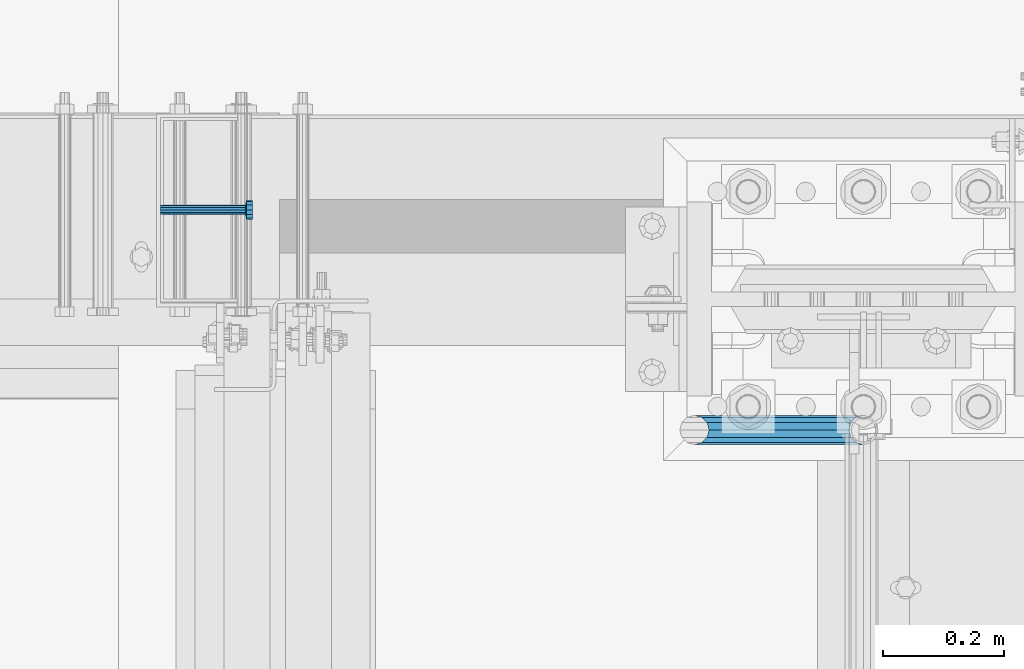
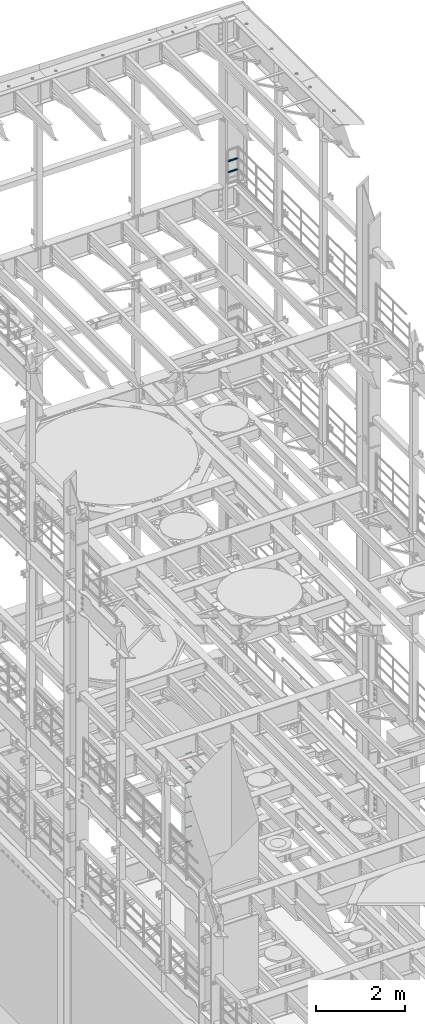
# One storey, part 1330 of 1876: 9 beams, 2 elements without a shape of their own.
"""IFC2X3 building model written with IfcOpenShell, lengths in millimetres."""

from ifc_helpers import new_model, si_unit, frame, origin_with_axes, place, context, subcontext, project, spatial, faceted_brep, material, type_object, element, aggregate, save


model = new_model("IFC2X3")

# Units and contexts
model_context = context("Model", 3, precision=1e-05, world=origin_with_axes())
body_context = subcontext(model_context, "Body", "Model", "MODEL_VIEW")
ifc_project = project(units=[si_unit("LENGTHUNIT", "METRE", prefix="MILLI"), si_unit("AREAUNIT", "SQUARE_METRE"), si_unit("VOLUMEUNIT", "CUBIC_METRE"), si_unit("MASSUNIT", "GRAM", prefix="KILO"), si_unit("TIMEUNIT", "SECOND"), si_unit("PLANEANGLEUNIT", "RADIAN"), si_unit("SOLIDANGLEUNIT", "STERADIAN"), si_unit("THERMODYNAMICTEMPERATUREUNIT", "DEGREE_CELSIUS"), si_unit("LUMINOUSINTENSITYUNIT", "LUMEN")], contexts=[model_context])

# Site, building, storey
site_placement = place(None, origin_with_axes())
site = spatial("IfcSite", under=ifc_project, at=site_placement, CompositionType="ELEMENT")
building_placement = place(site_placement, origin_with_axes())
building = spatial("IfcBuilding", under=site, at=building_placement, Name="Undefined", CompositionType="ELEMENT")
storey_placement = place(building_placement, origin_with_axes())
storey = spatial("IfcBuildingStorey", under=building, at=storey_placement, Name="Undefined", CompositionType="ELEMENT", Elevation=0.0)

# Assembly, beams
assembly_1_placement = place(storey_placement, origin_with_axes())
assembly_1 = element("IfcElementAssembly", 1, at=assembly_1_placement, inside=storey, Name="RAIL", AssemblyPlace="NOTDEFINED", PredefinedType="RIGID_FRAME")
ifc_material_1 = material()
beam_type_1 = type_object("IfcBeamType", Name="PIPE1-1/2SCH40", PredefinedType="NOTDEFINED")
beam_1_placement = place(assembly_1_placement, frame((7619.99999999999, 13499.7063, 18449.925000036), z_axis=(0.0, 0.0, 1.0), x_axis=(-1.0, 0.0, 0.0)))
beam_1 = element("IfcBeam", 2, at=beam_1_placement, type_object=beam_type_1, material=ifc_material_1, Name="RAIL", ObjectType="PIPE1-1/2SCH40", context=body_context, shape_type="Brep", body=[
    faceted_brep([(258.502800903171, -12.0650000000005, 20.8971929933177), (258.502800903171, -12.0650000000005, 15.8661214311796), (258.009372465309, -10.2235000000001, 17.7076214311819), (255.26999389649, 0.0, 20.4470000000001), (255.26999389649, 0.0, 24.130000000001), (258.009372465309, 10.2235000000001, 17.7076214311819), (258.502800903171, 12.0650000000005, 15.8661214311796), (258.502800903171, 12.0650000000005, 20.8971929933177), (279.399993896489, 24.1299999999992, 0.0), (267.33499389649, 20.8971929933177, 12.0649999999987), (267.33499389649, 20.8971929933177, -12.0649999999987), (264.145422334351, 17.7076214311801, 10.2235000000001), (266.884800903171, 20.4470000000001, 0.0), (264.145422334351, 17.7076214311801, -10.2235000000001), (258.502800903171, 12.0650000000005, -15.8661214311796), (258.502800903171, 12.0650000000005, -20.8971929933177), (258.009372465309, 10.2235000000001, -17.7076214311819), (255.26999389649, 0.0, -20.4470000000001), (255.26999389649, 0.0, -24.130000000001), (258.502800903171, -12.0650000000005, -15.8661214311796), (258.502800903171, -12.0650000000005, -20.8971929933177), (258.009372465309, -10.2235000000001, -17.7076214311819), (279.399993896489, -24.1299999999992, 0.0), (267.33499389649, -20.8971929933177, -12.0649999999987), (267.33499389649, -20.8971929933177, 12.0649999999987), (264.145422334351, -17.7076214311801, -10.2235000000001), (266.884800903171, -20.4470000000001, 0.0), (264.145422334351, -17.7076214311801, 10.2235000000001), (12.0650000000064, -20.8971929933177, -12.0649999999987), (20.8971929933249, -12.0650000000005, -20.8971929933177), (0.0, 24.1299999999992, 0.0), (12.0650000000064, 20.8971929933177, -12.0649999999987), (12.0650000000064, 20.8971929933177, 12.0649999999987), (20.8971929933249, 12.0650000000005, 20.8971929933177), (24.1300000000064, 0.0, 24.130000000001), (20.8971929933249, 12.0650000000005, -20.8971929933177), (24.1300000000063, 0.0, -24.130000000001), (24.1300000000063, 0.0, -20.4470000000001), (20.8971929933249, -12.0650000000005, -15.8661214311796), (21.3906214311868, -10.2235000000001, -17.7076214311819), (21.3906214311868, 10.2235000000001, -17.7076214311819), (20.8971929933249, 12.0650000000005, -15.8661214311796), (15.2545715621445, 17.7076214311801, -10.2235000000001), (12.5151929933249, 20.4470000000001, 0.0), (15.2545715621445, 17.7076214311801, 10.2235000000001), (20.8971929933249, 12.0650000000005, 15.8661214311796), (21.3906214311868, 10.2235000000001, 17.7076214311819), (24.1300000000064, 0.0, 20.4470000000001), (21.3906214311868, -10.2235000000001, 17.7076214311819), (20.8971929933249, -12.0650000000005, 15.8661214311796), (20.8971929933249, -12.0650000000005, 20.8971929933177), (12.0650000000064, -20.8971929933177, 12.0649999999987), (0.0, -24.1299999999992, 0.0), (15.2545715621445, -17.7076214311801, 10.2235000000001), (12.5151929933249, -20.4470000000001, 0.0), (15.2545715621445, -17.7076214311801, -10.2235000000001)], [[[0, 1, 2, 3, 4]], [[4, 3, 5, 6, 7]], [[8, 9, 10]], [[7, 6, 11, 12, 13, 14, 15, 10, 9]], [[16, 17, 18, 15, 14]], [[19, 20, 18, 17, 21]], [[22, 23, 24]], [[24, 23, 20, 19, 25, 26, 27, 1, 0]], [[28, 29, 20, 23]], [[30, 31, 32]], [[33, 34, 4, 7]], [[32, 33, 7, 9]], [[30, 32, 9, 8]], [[31, 30, 8, 10]], [[35, 31, 10, 15]], [[36, 35, 15, 18]], [[29, 36, 18, 20]], [[37, 36, 29, 38, 39]], [[40, 41, 35, 36, 37]], [[32, 31, 35, 41, 42, 43, 44, 45, 33]], [[33, 45, 46, 47, 34]], [[34, 47, 48, 49, 50]], [[34, 50, 0, 4]], [[50, 51, 24, 0]], [[51, 52, 22, 24]], [[52, 28, 23, 22]], [[51, 28, 52]], [[50, 49, 53, 54, 55, 38, 29, 28, 51]], [[55, 54, 26, 25]], [[21, 39, 38, 55, 25, 19]], [[37, 39, 21, 17]], [[40, 37, 17, 16]], [[42, 41, 40, 16, 14, 13]], [[43, 42, 13, 12]], [[44, 43, 12, 11]], [[5, 46, 45, 44, 11, 6]], [[47, 46, 5, 3]], [[48, 47, 3, 2]], [[53, 49, 48, 2, 1, 27]], [[54, 53, 27, 26]]]),
])
beam_2_placement = place(assembly_1_placement, frame((7619.99999999999, 13499.7063, 18754.7250000359), z_axis=(0.0, 0.0, 1.0), x_axis=(-1.0, 0.0, 0.0)))
beam_2 = element("IfcBeam", 3, at=beam_2_placement, type_object=beam_type_1, material=ifc_material_1, Name="RAIL", ObjectType="PIPE1-1/2SCH40", context=body_context, shape_type="Brep", body=[
    faceted_brep([(258.502800903171, -12.0650000000005, 20.8971929933177), (258.502800903171, -12.0650000000005, 15.8661214311796), (258.009372465309, -10.2235000000001, 17.7076214311819), (255.26999389649, 0.0, 20.4470000000001), (255.26999389649, 0.0, 24.130000000001), (258.009372465309, 10.2235000000001, 17.7076214311819), (258.502800903171, 12.0650000000005, 15.8661214311796), (258.502800903171, 12.0650000000005, 20.8971929933177), (279.399993896489, 24.1299999999992, 0.0), (267.33499389649, 20.8971929933177, 12.0649999999987), (267.33499389649, 20.8971929933177, -12.0649999999987), (264.145422334351, 17.7076214311801, 10.2235000000001), (266.884800903171, 20.4470000000001, 0.0), (264.145422334351, 17.7076214311801, -10.2235000000001), (258.502800903171, 12.0650000000005, -15.8661214311796), (258.502800903171, 12.0650000000005, -20.8971929933177), (258.009372465309, 10.2235000000001, -17.7076214311819), (255.26999389649, 0.0, -20.4470000000001), (255.26999389649, 0.0, -24.130000000001), (258.502800903171, -12.0650000000005, -15.8661214311796), (258.502800903171, -12.0650000000005, -20.8971929933177), (258.009372465309, -10.2235000000001, -17.7076214311819), (279.399993896489, -24.1299999999992, 0.0), (267.33499389649, -20.8971929933177, -12.0649999999987), (267.33499389649, -20.8971929933177, 12.0649999999987), (264.145422334351, -17.7076214311801, -10.2235000000001), (266.884800903171, -20.4470000000001, 0.0), (264.145422334351, -17.7076214311801, 10.2235000000001), (12.0650000000064, -20.8971929933177, -12.0649999999987), (20.8971929933249, -12.0650000000005, -20.8971929933177), (0.0, 24.1299999999992, 0.0), (12.0650000000064, 20.8971929933177, -12.0649999999987), (12.0650000000064, 20.8971929933177, 12.0649999999987), (20.8971929933249, 12.0650000000005, 20.8971929933177), (24.1300000000064, 0.0, 24.130000000001), (20.8971929933249, 12.0650000000005, -20.8971929933177), (24.1300000000063, 0.0, -24.130000000001), (24.1300000000063, 0.0, -20.4470000000001), (20.8971929933249, -12.0650000000005, -15.8661214311796), (21.3906214311868, -10.2235000000001, -17.7076214311819), (21.3906214311868, 10.2235000000001, -17.7076214311819), (20.8971929933249, 12.0650000000005, -15.8661214311796), (15.2545715621445, 17.7076214311801, -10.2235000000001), (12.5151929933249, 20.4470000000001, 0.0), (15.2545715621445, 17.7076214311801, 10.2235000000001), (20.8971929933249, 12.0650000000005, 15.8661214311796), (21.3906214311868, 10.2235000000001, 17.7076214311819), (24.1300000000064, 0.0, 20.4470000000001), (21.3906214311868, -10.2235000000001, 17.7076214311819), (20.8971929933249, -12.0650000000005, 15.8661214311796), (20.8971929933249, -12.0650000000005, 20.8971929933177), (12.0650000000064, -20.8971929933177, 12.0649999999987), (0.0, -24.1299999999992, 0.0), (15.2545715621445, -17.7076214311801, 10.2235000000001), (12.5151929933249, -20.4470000000001, 0.0), (15.2545715621445, -17.7076214311801, -10.2235000000001)], [[[0, 1, 2, 3, 4]], [[4, 3, 5, 6, 7]], [[8, 9, 10]], [[7, 6, 11, 12, 13, 14, 15, 10, 9]], [[16, 17, 18, 15, 14]], [[19, 20, 18, 17, 21]], [[22, 23, 24]], [[24, 23, 20, 19, 25, 26, 27, 1, 0]], [[28, 29, 20, 23]], [[30, 31, 32]], [[33, 34, 4, 7]], [[32, 33, 7, 9]], [[30, 32, 9, 8]], [[31, 30, 8, 10]], [[35, 31, 10, 15]], [[36, 35, 15, 18]], [[29, 36, 18, 20]], [[37, 36, 29, 38, 39]], [[40, 41, 35, 36, 37]], [[32, 31, 35, 41, 42, 43, 44, 45, 33]], [[33, 45, 46, 47, 34]], [[34, 47, 48, 49, 50]], [[34, 50, 0, 4]], [[50, 51, 24, 0]], [[51, 52, 22, 24]], [[52, 28, 23, 22]], [[51, 28, 52]], [[50, 49, 53, 54, 55, 38, 29, 28, 51]], [[55, 54, 26, 25]], [[21, 39, 38, 55, 25, 19]], [[37, 39, 21, 17]], [[40, 37, 17, 16]], [[42, 41, 40, 16, 14, 13]], [[43, 42, 13, 12]], [[44, 43, 12, 11]], [[5, 46, 45, 44, 11, 6]], [[47, 46, 5, 3]], [[48, 47, 3, 2]], [[53, 49, 48, 2, 1, 27]], [[54, 53, 27, 26]]]),
])
aggregate(assembly_1, [beam_1, beam_2])

assembly_2_placement = place(storey_placement, origin_with_axes())
assembly_2 = element("IfcElementAssembly", 4, at=assembly_2_placement, inside=storey, Name="BENT PLATE", AssemblyPlace="NOTDEFINED", PredefinedType="RIGID_FRAME")
ifc_material_2 = material(Name="STEEL/A108")
beam_type_2 = type_object("IfcBeamType", Name="STUD_5/8-DIA", PredefinedType="NOTDEFINED")
beam_3_placement = place(assembly_2_placement, frame((6457.95144692033, 13863.6374842527, 2540.0), z_axis=(0.0, 0.0, 1.0), x_axis=(1.0, 0.0, 0.0)))
beam_3 = element("IfcBeam", 5, at=beam_3_placement, type_object=beam_type_2, material=ifc_material_2, Name="WELDED HEADED STUD", ObjectType="STUD_5/8-DIA", context=body_context, shape_type="Brep", body=[
    faceted_brep([(0.0, -7.94000005722046, 0.0), (0.0, -6.86999988555908, -3.97000002861023), (140.207082738083, -6.86999988555908, -3.97000002861023), (140.207082738083, -7.94000005722046, 0.0), (0.0, -3.97000002861023, -6.86999988555908), (140.207082738083, -3.97000002861023, -6.86999988555908), (0.0, 0.0, -7.94000005722046), (140.207082738083, 0.0, -7.94000005722046), (0.0, 3.97000002861023, -6.86999988555908), (140.207082738083, 3.97000002861023, -6.86999988555908), (0.0, 6.86999988555908, -3.97000002861023), (140.207082738083, 6.86999988555908, -3.97000002861023), (0.0, 7.94000005722046, 0.0), (140.207082738083, 7.94000005722046, 0.0), (0.0, 6.86999988555908, 3.97000002861023), (140.207082738083, 6.86999988555908, 3.97000002861023), (0.0, 3.97000002861023, 6.86999988555908), (140.207082738083, 3.97000002861023, 6.86999988555908), (0.0, 0.0, 7.94000005722046), (140.207082738083, 0.0, 7.94000005722046), (0.0, -3.97000002861023, 6.86999988555908), (140.207082738083, -3.97000002861023, 6.86999988555908), (0.0, -6.86999988555908, 3.97000002861023), (140.207082738083, -6.86999988555908, 3.97000002861023), (141.731072767845, -13.75, -7.94000005722046), (141.731072767845, -15.8800001144409, 0.0), (141.731072767845, -7.94000005722046, -13.75), (141.731072767845, 0.0, -15.8800001144409), (141.731072767845, 7.94000005722046, -13.75), (141.731072767845, 13.75, -7.94000005722046), (141.731072767845, 15.8800001144409, 0.0), (141.731072767845, 13.75, 7.94000005722046), (141.731072767845, 7.94000005722046, 13.75), (141.731072767845, 0.0, 15.8800001144409), (141.731072767845, -7.94000005722046, 13.75), (141.731072767845, -13.75, 7.94000005722046), (152.399002976177, -13.75, -7.94000005722046), (152.399002976177, -15.8800001144409, 0.0), (152.399002976177, -7.94000005722046, -13.75), (152.399002976177, 0.0, -15.8800001144409), (152.399002976177, 7.94000005722046, -13.75), (152.399002976177, 13.75, -7.94000005722046), (152.399002976177, 15.8800001144409, 0.0), (152.399002976177, 13.75, 7.94000005722046), (152.399002976177, 7.94000005722046, 13.75), (152.399002976177, 0.0, 15.8800001144409), (152.399002976177, -7.94000005722046, 13.75), (152.399002976177, -13.75, 7.94000005722046)], [[[0, 1, 2, 3]], [[1, 4, 5, 2]], [[4, 6, 7, 5]], [[6, 8, 9, 7]], [[8, 10, 11, 9]], [[10, 12, 13, 11]], [[12, 14, 15, 13]], [[14, 16, 17, 15]], [[16, 18, 19, 17]], [[18, 20, 21, 19]], [[20, 22, 23, 21]], [[22, 0, 3, 23]], [[22, 20, 18, 16, 14, 12, 10, 8, 6, 4, 1, 0]], [[3, 2, 24, 25]], [[2, 5, 26, 24]], [[5, 7, 27, 26]], [[7, 9, 28, 27]], [[9, 11, 29, 28]], [[11, 13, 30, 29]], [[13, 15, 31, 30]], [[15, 17, 32, 31]], [[17, 19, 33, 32]], [[19, 21, 34, 33]], [[21, 23, 35, 34]], [[23, 3, 25, 35]], [[25, 24, 36, 37]], [[24, 26, 38, 36]], [[26, 27, 39, 38]], [[27, 28, 40, 39]], [[28, 29, 41, 40]], [[29, 30, 42, 41]], [[30, 31, 43, 42]], [[31, 32, 44, 43]], [[32, 33, 45, 44]], [[33, 34, 46, 45]], [[34, 35, 47, 46]], [[35, 25, 37, 47]], [[38, 39, 40, 41, 42, 43, 44, 45, 46, 47, 37, 36]]]),
])
beam_4_placement = place(assembly_2_placement, frame((6457.95144692033, 13863.6374842527, 2133.6), z_axis=(0.0, 0.0, 1.0), x_axis=(1.0, 0.0, 0.0)))
beam_4 = element("IfcBeam", 6, at=beam_4_placement, type_object=beam_type_2, material=ifc_material_2, Name="WELDED HEADED STUD", ObjectType="STUD_5/8-DIA", context=body_context, shape_type="Brep", body=[
    faceted_brep([(0.0, -7.94000005722046, 0.0), (0.0, -6.86999988555908, -3.97000002861023), (140.207082738083, -6.86999988555908, -3.97000002861023), (140.207082738083, -7.94000005722046, 0.0), (0.0, -3.97000002861023, -6.86999988555908), (140.207082738083, -3.97000002861023, -6.86999988555908), (0.0, 0.0, -7.94000005722046), (140.207082738083, 0.0, -7.94000005722046), (0.0, 3.97000002861023, -6.86999988555908), (140.207082738083, 3.97000002861023, -6.86999988555908), (0.0, 6.86999988555908, -3.97000002861023), (140.207082738083, 6.86999988555908, -3.97000002861023), (0.0, 7.94000005722046, 0.0), (140.207082738083, 7.94000005722046, 0.0), (0.0, 6.86999988555908, 3.97000002861023), (140.207082738083, 6.86999988555908, 3.97000002861023), (0.0, 3.97000002861023, 6.86999988555908), (140.207082738083, 3.97000002861023, 6.86999988555908), (0.0, 0.0, 7.94000005722046), (140.207082738083, 0.0, 7.94000005722046), (0.0, -3.97000002861023, 6.86999988555908), (140.207082738083, -3.97000002861023, 6.86999988555908), (0.0, -6.86999988555908, 3.97000002861023), (140.207082738083, -6.86999988555908, 3.97000002861023), (141.731072767845, -13.75, -7.94000005722046), (141.731072767845, -15.8800001144409, 0.0), (141.731072767845, -7.94000005722046, -13.75), (141.731072767845, 0.0, -15.8800001144409), (141.731072767845, 7.94000005722046, -13.75), (141.731072767845, 13.75, -7.94000005722046), (141.731072767845, 15.8800001144409, 0.0), (141.731072767845, 13.75, 7.94000005722046), (141.731072767845, 7.94000005722046, 13.75), (141.731072767845, 0.0, 15.8800001144409), (141.731072767845, -7.94000005722046, 13.75), (141.731072767845, -13.75, 7.94000005722046), (152.399002976177, -13.75, -7.94000005722046), (152.399002976177, -15.8800001144409, 0.0), (152.399002976177, -7.94000005722046, -13.75), (152.399002976177, 0.0, -15.8800001144409), (152.399002976177, 7.94000005722046, -13.75), (152.399002976177, 13.75, -7.94000005722046), (152.399002976177, 15.8800001144409, 0.0), (152.399002976177, 13.75, 7.94000005722046), (152.399002976177, 7.94000005722046, 13.75), (152.399002976177, 0.0, 15.8800001144409), (152.399002976177, -7.94000005722046, 13.75), (152.399002976177, -13.75, 7.94000005722046)], [[[0, 1, 2, 3]], [[1, 4, 5, 2]], [[4, 6, 7, 5]], [[6, 8, 9, 7]], [[8, 10, 11, 9]], [[10, 12, 13, 11]], [[12, 14, 15, 13]], [[14, 16, 17, 15]], [[16, 18, 19, 17]], [[18, 20, 21, 19]], [[20, 22, 23, 21]], [[22, 0, 3, 23]], [[22, 20, 18, 16, 14, 12, 10, 8, 6, 4, 1, 0]], [[3, 2, 24, 25]], [[2, 5, 26, 24]], [[5, 7, 27, 26]], [[7, 9, 28, 27]], [[9, 11, 29, 28]], [[11, 13, 30, 29]], [[13, 15, 31, 30]], [[15, 17, 32, 31]], [[17, 19, 33, 32]], [[19, 21, 34, 33]], [[21, 23, 35, 34]], [[23, 3, 25, 35]], [[25, 24, 36, 37]], [[24, 26, 38, 36]], [[26, 27, 39, 38]], [[27, 28, 40, 39]], [[28, 29, 41, 40]], [[29, 30, 42, 41]], [[30, 31, 43, 42]], [[31, 32, 44, 43]], [[32, 33, 45, 44]], [[33, 34, 46, 45]], [[34, 35, 47, 46]], [[35, 25, 37, 47]], [[38, 39, 40, 41, 42, 43, 44, 45, 46, 47, 37, 36]]]),
])
beam_5_placement = place(assembly_2_placement, frame((6457.95144692033, 13863.6374842527, 1727.2), z_axis=(0.0, 0.0, 1.0), x_axis=(1.0, 0.0, 0.0)))
beam_5 = element("IfcBeam", 7, at=beam_5_placement, type_object=beam_type_2, material=ifc_material_2, Name="WELDED HEADED STUD", ObjectType="STUD_5/8-DIA", context=body_context, shape_type="Brep", body=[
    faceted_brep([(0.0, -7.94000005722046, 0.0), (0.0, -6.86999988555908, -3.97000002861023), (140.207082738083, -6.86999988555908, -3.97000002861023), (140.207082738083, -7.94000005722046, 0.0), (0.0, -3.97000002861023, -6.86999988555908), (140.207082738083, -3.97000002861023, -6.86999988555908), (0.0, 0.0, -7.94000005722046), (140.207082738083, 0.0, -7.94000005722046), (0.0, 3.97000002861023, -6.86999988555908), (140.207082738083, 3.97000002861023, -6.86999988555908), (0.0, 6.86999988555908, -3.97000002861023), (140.207082738083, 6.86999988555908, -3.97000002861023), (0.0, 7.94000005722046, 0.0), (140.207082738083, 7.94000005722046, 0.0), (0.0, 6.86999988555908, 3.97000002861023), (140.207082738083, 6.86999988555908, 3.97000002861023), (0.0, 3.97000002861023, 6.86999988555908), (140.207082738083, 3.97000002861023, 6.86999988555908), (0.0, 0.0, 7.94000005722046), (140.207082738083, 0.0, 7.94000005722046), (0.0, -3.97000002861023, 6.86999988555908), (140.207082738083, -3.97000002861023, 6.86999988555908), (0.0, -6.86999988555908, 3.97000002861023), (140.207082738083, -6.86999988555908, 3.97000002861023), (141.731072767845, -13.75, -7.94000005722046), (141.731072767845, -15.8800001144409, 0.0), (141.731072767845, -7.94000005722046, -13.75), (141.731072767845, 0.0, -15.8800001144409), (141.731072767845, 7.94000005722046, -13.75), (141.731072767845, 13.75, -7.94000005722046), (141.731072767845, 15.8800001144409, 0.0), (141.731072767845, 13.75, 7.94000005722046), (141.731072767845, 7.94000005722046, 13.75), (141.731072767845, 0.0, 15.8800001144409), (141.731072767845, -7.94000005722046, 13.75), (141.731072767845, -13.75, 7.94000005722046), (152.399002976177, -13.75, -7.94000005722046), (152.399002976177, -15.8800001144409, 0.0), (152.399002976177, -7.94000005722046, -13.75), (152.399002976177, 0.0, -15.8800001144409), (152.399002976177, 7.94000005722046, -13.75), (152.399002976177, 13.75, -7.94000005722046), (152.399002976177, 15.8800001144409, 0.0), (152.399002976177, 13.75, 7.94000005722046), (152.399002976177, 7.94000005722046, 13.75), (152.399002976177, 0.0, 15.8800001144409), (152.399002976177, -7.94000005722046, 13.75), (152.399002976177, -13.75, 7.94000005722046)], [[[0, 1, 2, 3]], [[1, 4, 5, 2]], [[4, 6, 7, 5]], [[6, 8, 9, 7]], [[8, 10, 11, 9]], [[10, 12, 13, 11]], [[12, 14, 15, 13]], [[14, 16, 17, 15]], [[16, 18, 19, 17]], [[18, 20, 21, 19]], [[20, 22, 23, 21]], [[22, 0, 3, 23]], [[22, 20, 18, 16, 14, 12, 10, 8, 6, 4, 1, 0]], [[3, 2, 24, 25]], [[2, 5, 26, 24]], [[5, 7, 27, 26]], [[7, 9, 28, 27]], [[9, 11, 29, 28]], [[11, 13, 30, 29]], [[13, 15, 31, 30]], [[15, 17, 32, 31]], [[17, 19, 33, 32]], [[19, 21, 34, 33]], [[21, 23, 35, 34]], [[23, 3, 25, 35]], [[25, 24, 36, 37]], [[24, 26, 38, 36]], [[26, 27, 39, 38]], [[27, 28, 40, 39]], [[28, 29, 41, 40]], [[29, 30, 42, 41]], [[30, 31, 43, 42]], [[31, 32, 44, 43]], [[32, 33, 45, 44]], [[33, 34, 46, 45]], [[34, 35, 47, 46]], [[35, 25, 37, 47]], [[38, 39, 40, 41, 42, 43, 44, 45, 46, 47, 37, 36]]]),
])
beam_6_placement = place(assembly_2_placement, frame((6457.95144692033, 13863.6374842527, 1320.8), z_axis=(0.0, 0.0, 1.0), x_axis=(1.0, 0.0, 0.0)))
beam_6 = element("IfcBeam", 8, at=beam_6_placement, type_object=beam_type_2, material=ifc_material_2, Name="WELDED HEADED STUD", ObjectType="STUD_5/8-DIA", context=body_context, shape_type="Brep", body=[
    faceted_brep([(0.0, -7.94000005722046, 0.0), (0.0, -6.86999988555908, -3.97000002861023), (140.207082738083, -6.86999988555908, -3.97000002861023), (140.207082738083, -7.94000005722046, 0.0), (0.0, -3.97000002861023, -6.86999988555908), (140.207082738083, -3.97000002861023, -6.86999988555908), (0.0, 0.0, -7.94000005722046), (140.207082738083, 0.0, -7.94000005722046), (0.0, 3.97000002861023, -6.86999988555908), (140.207082738083, 3.97000002861023, -6.86999988555908), (0.0, 6.86999988555908, -3.97000002861023), (140.207082738083, 6.86999988555908, -3.97000002861023), (0.0, 7.94000005722046, 0.0), (140.207082738083, 7.94000005722046, 0.0), (0.0, 6.86999988555908, 3.97000002861023), (140.207082738083, 6.86999988555908, 3.97000002861023), (0.0, 3.97000002861023, 6.86999988555908), (140.207082738083, 3.97000002861023, 6.86999988555908), (0.0, 0.0, 7.94000005722046), (140.207082738083, 0.0, 7.94000005722046), (0.0, -3.97000002861023, 6.86999988555908), (140.207082738083, -3.97000002861023, 6.86999988555908), (0.0, -6.86999988555908, 3.97000002861023), (140.207082738083, -6.86999988555908, 3.97000002861023), (141.731072767845, -13.75, -7.94000005722046), (141.731072767845, -15.8800001144409, 0.0), (141.731072767845, -7.94000005722046, -13.75), (141.731072767845, 0.0, -15.8800001144409), (141.731072767845, 7.94000005722046, -13.75), (141.731072767845, 13.75, -7.94000005722046), (141.731072767845, 15.8800001144409, 0.0), (141.731072767845, 13.75, 7.94000005722046), (141.731072767845, 7.94000005722046, 13.75), (141.731072767845, 0.0, 15.8800001144409), (141.731072767845, -7.94000005722046, 13.75), (141.731072767845, -13.75, 7.94000005722046), (152.399002976177, -13.75, -7.94000005722046), (152.399002976177, -15.8800001144409, 0.0), (152.399002976177, -7.94000005722046, -13.75), (152.399002976177, 0.0, -15.8800001144409), (152.399002976177, 7.94000005722046, -13.75), (152.399002976177, 13.75, -7.94000005722046), (152.399002976177, 15.8800001144409, 0.0), (152.399002976177, 13.75, 7.94000005722046), (152.399002976177, 7.94000005722046, 13.75), (152.399002976177, 0.0, 15.8800001144409), (152.399002976177, -7.94000005722046, 13.75), (152.399002976177, -13.75, 7.94000005722046)], [[[0, 1, 2, 3]], [[1, 4, 5, 2]], [[4, 6, 7, 5]], [[6, 8, 9, 7]], [[8, 10, 11, 9]], [[10, 12, 13, 11]], [[12, 14, 15, 13]], [[14, 16, 17, 15]], [[16, 18, 19, 17]], [[18, 20, 21, 19]], [[20, 22, 23, 21]], [[22, 0, 3, 23]], [[22, 20, 18, 16, 14, 12, 10, 8, 6, 4, 1, 0]], [[3, 2, 24, 25]], [[2, 5, 26, 24]], [[5, 7, 27, 26]], [[7, 9, 28, 27]], [[9, 11, 29, 28]], [[11, 13, 30, 29]], [[13, 15, 31, 30]], [[15, 17, 32, 31]], [[17, 19, 33, 32]], [[19, 21, 34, 33]], [[21, 23, 35, 34]], [[23, 3, 25, 35]], [[25, 24, 36, 37]], [[24, 26, 38, 36]], [[26, 27, 39, 38]], [[27, 28, 40, 39]], [[28, 29, 41, 40]], [[29, 30, 42, 41]], [[30, 31, 43, 42]], [[31, 32, 44, 43]], [[32, 33, 45, 44]], [[33, 34, 46, 45]], [[34, 35, 47, 46]], [[35, 25, 37, 47]], [[38, 39, 40, 41, 42, 43, 44, 45, 46, 47, 37, 36]]]),
])
beam_7_placement = place(assembly_2_placement, frame((6457.95144692033, 13863.6374842527, 914.4), z_axis=(0.0, 0.0, 1.0), x_axis=(1.0, 0.0, 0.0)))
beam_7 = element("IfcBeam", 9, at=beam_7_placement, type_object=beam_type_2, material=ifc_material_2, Name="WELDED HEADED STUD", ObjectType="STUD_5/8-DIA", context=body_context, shape_type="Brep", body=[
    faceted_brep([(0.0, -7.94000005722046, 0.0), (0.0, -6.86999988555908, -3.97000002861023), (140.207082738083, -6.86999988555908, -3.97000002861023), (140.207082738083, -7.94000005722046, 0.0), (0.0, -3.97000002861023, -6.86999988555908), (140.207082738083, -3.97000002861023, -6.86999988555908), (0.0, 0.0, -7.94000005722046), (140.207082738083, 0.0, -7.94000005722046), (0.0, 3.97000002861023, -6.86999988555908), (140.207082738083, 3.97000002861023, -6.86999988555908), (0.0, 6.86999988555908, -3.97000002861023), (140.207082738083, 6.86999988555908, -3.97000002861023), (0.0, 7.94000005722046, 0.0), (140.207082738083, 7.94000005722046, 0.0), (0.0, 6.86999988555908, 3.97000002861023), (140.207082738083, 6.86999988555908, 3.97000002861023), (0.0, 3.97000002861023, 6.86999988555908), (140.207082738083, 3.97000002861023, 6.86999988555908), (0.0, 0.0, 7.94000005722046), (140.207082738083, 0.0, 7.94000005722046), (0.0, -3.97000002861023, 6.86999988555908), (140.207082738083, -3.97000002861023, 6.86999988555908), (0.0, -6.86999988555908, 3.97000002861023), (140.207082738083, -6.86999988555908, 3.97000002861023), (141.731072767845, -13.75, -7.94000005722046), (141.731072767845, -15.8800001144409, 0.0), (141.731072767845, -7.94000005722046, -13.75), (141.731072767845, 0.0, -15.8800001144409), (141.731072767845, 7.94000005722046, -13.75), (141.731072767845, 13.75, -7.94000005722046), (141.731072767845, 15.8800001144409, 0.0), (141.731072767845, 13.75, 7.94000005722046), (141.731072767845, 7.94000005722046, 13.75), (141.731072767845, 0.0, 15.8800001144409), (141.731072767845, -7.94000005722046, 13.75), (141.731072767845, -13.75, 7.94000005722046), (152.399002976177, -13.75, -7.94000005722046), (152.399002976177, -15.8800001144409, 0.0), (152.399002976177, -7.94000005722046, -13.75), (152.399002976177, 0.0, -15.8800001144409), (152.399002976177, 7.94000005722046, -13.75), (152.399002976177, 13.75, -7.94000005722046), (152.399002976177, 15.8800001144409, 0.0), (152.399002976177, 13.75, 7.94000005722046), (152.399002976177, 7.94000005722046, 13.75), (152.399002976177, 0.0, 15.8800001144409), (152.399002976177, -7.94000005722046, 13.75), (152.399002976177, -13.75, 7.94000005722046)], [[[0, 1, 2, 3]], [[1, 4, 5, 2]], [[4, 6, 7, 5]], [[6, 8, 9, 7]], [[8, 10, 11, 9]], [[10, 12, 13, 11]], [[12, 14, 15, 13]], [[14, 16, 17, 15]], [[16, 18, 19, 17]], [[18, 20, 21, 19]], [[20, 22, 23, 21]], [[22, 0, 3, 23]], [[22, 20, 18, 16, 14, 12, 10, 8, 6, 4, 1, 0]], [[3, 2, 24, 25]], [[2, 5, 26, 24]], [[5, 7, 27, 26]], [[7, 9, 28, 27]], [[9, 11, 29, 28]], [[11, 13, 30, 29]], [[13, 15, 31, 30]], [[15, 17, 32, 31]], [[17, 19, 33, 32]], [[19, 21, 34, 33]], [[21, 23, 35, 34]], [[23, 3, 25, 35]], [[25, 24, 36, 37]], [[24, 26, 38, 36]], [[26, 27, 39, 38]], [[27, 28, 40, 39]], [[28, 29, 41, 40]], [[29, 30, 42, 41]], [[30, 31, 43, 42]], [[31, 32, 44, 43]], [[32, 33, 45, 44]], [[33, 34, 46, 45]], [[34, 35, 47, 46]], [[35, 25, 37, 47]], [[38, 39, 40, 41, 42, 43, 44, 45, 46, 47, 37, 36]]]),
])
beam_8_placement = place(assembly_2_placement, frame((6457.95144692033, 13863.6374842527, 508.0), z_axis=(0.0, 0.0, 1.0), x_axis=(1.0, 0.0, 0.0)))
beam_8 = element("IfcBeam", 10, at=beam_8_placement, type_object=beam_type_2, material=ifc_material_2, Name="WELDED HEADED STUD", ObjectType="STUD_5/8-DIA", context=body_context, shape_type="Brep", body=[
    faceted_brep([(0.0, -7.94000005722046, 0.0), (0.0, -6.86999988555908, -3.97000002861023), (140.207082738083, -6.86999988555908, -3.97000002861023), (140.207082738083, -7.94000005722046, 0.0), (0.0, -3.97000002861023, -6.86999988555908), (140.207082738083, -3.97000002861023, -6.86999988555908), (0.0, 0.0, -7.94000005722046), (140.207082738083, 0.0, -7.94000005722046), (0.0, 3.97000002861023, -6.86999988555908), (140.207082738083, 3.97000002861023, -6.86999988555908), (0.0, 6.86999988555908, -3.97000002861023), (140.207082738083, 6.86999988555908, -3.97000002861023), (0.0, 7.94000005722046, 0.0), (140.207082738083, 7.94000005722046, 0.0), (0.0, 6.86999988555908, 3.97000002861023), (140.207082738083, 6.86999988555908, 3.97000002861023), (0.0, 3.97000002861023, 6.86999988555908), (140.207082738083, 3.97000002861023, 6.86999988555908), (0.0, 0.0, 7.94000005722046), (140.207082738083, 0.0, 7.94000005722046), (0.0, -3.97000002861023, 6.86999988555908), (140.207082738083, -3.97000002861023, 6.86999988555908), (0.0, -6.86999988555908, 3.97000002861023), (140.207082738083, -6.86999988555908, 3.97000002861023), (141.731072767845, -13.75, -7.94000005722046), (141.731072767845, -15.8800001144409, 0.0), (141.731072767845, -7.94000005722046, -13.75), (141.731072767845, 0.0, -15.8800001144409), (141.731072767845, 7.94000005722046, -13.75), (141.731072767845, 13.75, -7.94000005722046), (141.731072767845, 15.8800001144409, 0.0), (141.731072767845, 13.75, 7.94000005722046), (141.731072767845, 7.94000005722046, 13.75), (141.731072767845, 0.0, 15.8800001144409), (141.731072767845, -7.94000005722046, 13.75), (141.731072767845, -13.75, 7.94000005722046), (152.399002976177, -13.75, -7.94000005722046), (152.399002976177, -15.8800001144409, 0.0), (152.399002976177, -7.94000005722046, -13.75), (152.399002976177, 0.0, -15.8800001144409), (152.399002976177, 7.94000005722046, -13.75), (152.399002976177, 13.75, -7.94000005722046), (152.399002976177, 15.8800001144409, 0.0), (152.399002976177, 13.75, 7.94000005722046), (152.399002976177, 7.94000005722046, 13.75), (152.399002976177, 0.0, 15.8800001144409), (152.399002976177, -7.94000005722046, 13.75), (152.399002976177, -13.75, 7.94000005722046)], [[[0, 1, 2, 3]], [[1, 4, 5, 2]], [[4, 6, 7, 5]], [[6, 8, 9, 7]], [[8, 10, 11, 9]], [[10, 12, 13, 11]], [[12, 14, 15, 13]], [[14, 16, 17, 15]], [[16, 18, 19, 17]], [[18, 20, 21, 19]], [[20, 22, 23, 21]], [[22, 0, 3, 23]], [[22, 20, 18, 16, 14, 12, 10, 8, 6, 4, 1, 0]], [[3, 2, 24, 25]], [[2, 5, 26, 24]], [[5, 7, 27, 26]], [[7, 9, 28, 27]], [[9, 11, 29, 28]], [[11, 13, 30, 29]], [[13, 15, 31, 30]], [[15, 17, 32, 31]], [[17, 19, 33, 32]], [[19, 21, 34, 33]], [[21, 23, 35, 34]], [[23, 3, 25, 35]], [[25, 24, 36, 37]], [[24, 26, 38, 36]], [[26, 27, 39, 38]], [[27, 28, 40, 39]], [[28, 29, 41, 40]], [[29, 30, 42, 41]], [[30, 31, 43, 42]], [[31, 32, 44, 43]], [[32, 33, 45, 44]], [[33, 34, 46, 45]], [[34, 35, 47, 46]], [[35, 25, 37, 47]], [[38, 39, 40, 41, 42, 43, 44, 45, 46, 47, 37, 36]]]),
])
beam_9_placement = place(assembly_2_placement, frame((6457.95144692033, 13863.6374842527, 101.6), z_axis=(0.0, 0.0, 1.0), x_axis=(1.0, 0.0, 0.0)))
beam_9 = element("IfcBeam", 11, at=beam_9_placement, type_object=beam_type_2, material=ifc_material_2, Name="WELDED HEADED STUD", ObjectType="STUD_5/8-DIA", context=body_context, shape_type="Brep", body=[
    faceted_brep([(0.0, -7.94000005722046, 0.0), (0.0, -6.86999988555908, -3.97000002861023), (140.207082738083, -6.86999988555908, -3.97000002861023), (140.207082738083, -7.94000005722046, 0.0), (0.0, -3.97000002861023, -6.86999988555908), (140.207082738083, -3.97000002861023, -6.86999988555908), (0.0, 0.0, -7.94000005722046), (140.207082738083, 0.0, -7.94000005722046), (0.0, 3.97000002861023, -6.86999988555908), (140.207082738083, 3.97000002861023, -6.86999988555908), (0.0, 6.86999988555908, -3.97000002861023), (140.207082738083, 6.86999988555908, -3.97000002861023), (0.0, 7.94000005722046, 0.0), (140.207082738083, 7.94000005722046, 0.0), (0.0, 6.86999988555908, 3.97000002861023), (140.207082738083, 6.86999988555908, 3.97000002861023), (0.0, 3.97000002861023, 6.86999988555908), (140.207082738083, 3.97000002861023, 6.86999988555908), (0.0, 0.0, 7.94000005722046), (140.207082738083, 0.0, 7.94000005722046), (0.0, -3.97000002861023, 6.86999988555908), (140.207082738083, -3.97000002861023, 6.86999988555908), (0.0, -6.86999988555908, 3.97000002861023), (140.207082738083, -6.86999988555908, 3.97000002861023), (141.731072767845, -13.75, -7.94000005722046), (141.731072767845, -15.8800001144409, 0.0), (141.731072767845, -7.94000005722046, -13.75), (141.731072767845, 0.0, -15.8800001144409), (141.731072767845, 7.94000005722046, -13.75), (141.731072767845, 13.75, -7.94000005722046), (141.731072767845, 15.8800001144409, 0.0), (141.731072767845, 13.75, 7.94000005722046), (141.731072767845, 7.94000005722046, 13.75), (141.731072767845, 0.0, 15.8800001144409), (141.731072767845, -7.94000005722046, 13.75), (141.731072767845, -13.75, 7.94000005722046), (152.399002976177, -13.75, -7.94000005722046), (152.399002976177, -15.8800001144409, 0.0), (152.399002976177, -7.94000005722046, -13.75), (152.399002976177, 0.0, -15.8800001144409), (152.399002976177, 7.94000005722046, -13.75), (152.399002976177, 13.75, -7.94000005722046), (152.399002976177, 15.8800001144409, 0.0), (152.399002976177, 13.75, 7.94000005722046), (152.399002976177, 7.94000005722046, 13.75), (152.399002976177, 0.0, 15.8800001144409), (152.399002976177, -7.94000005722046, 13.75), (152.399002976177, -13.75, 7.94000005722046)], [[[0, 1, 2, 3]], [[1, 4, 5, 2]], [[4, 6, 7, 5]], [[6, 8, 9, 7]], [[8, 10, 11, 9]], [[10, 12, 13, 11]], [[12, 14, 15, 13]], [[14, 16, 17, 15]], [[16, 18, 19, 17]], [[18, 20, 21, 19]], [[20, 22, 23, 21]], [[22, 0, 3, 23]], [[22, 20, 18, 16, 14, 12, 10, 8, 6, 4, 1, 0]], [[3, 2, 24, 25]], [[2, 5, 26, 24]], [[5, 7, 27, 26]], [[7, 9, 28, 27]], [[9, 11, 29, 28]], [[11, 13, 30, 29]], [[13, 15, 31, 30]], [[15, 17, 32, 31]], [[17, 19, 33, 32]], [[19, 21, 34, 33]], [[21, 23, 35, 34]], [[23, 3, 25, 35]], [[25, 24, 36, 37]], [[24, 26, 38, 36]], [[26, 27, 39, 38]], [[27, 28, 40, 39]], [[28, 29, 41, 40]], [[29, 30, 42, 41]], [[30, 31, 43, 42]], [[31, 32, 44, 43]], [[32, 33, 45, 44]], [[33, 34, 46, 45]], [[34, 35, 47, 46]], [[35, 25, 37, 47]], [[38, 39, 40, 41, 42, 43, 44, 45, 46, 47, 37, 36]]]),
])
aggregate(assembly_2, [beam_3, beam_4, beam_5, beam_6, beam_7, beam_8, beam_9])

save(model, "model.ifc")
